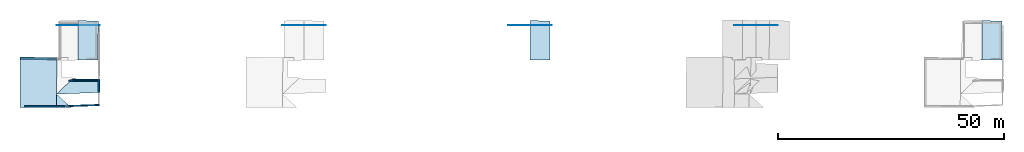
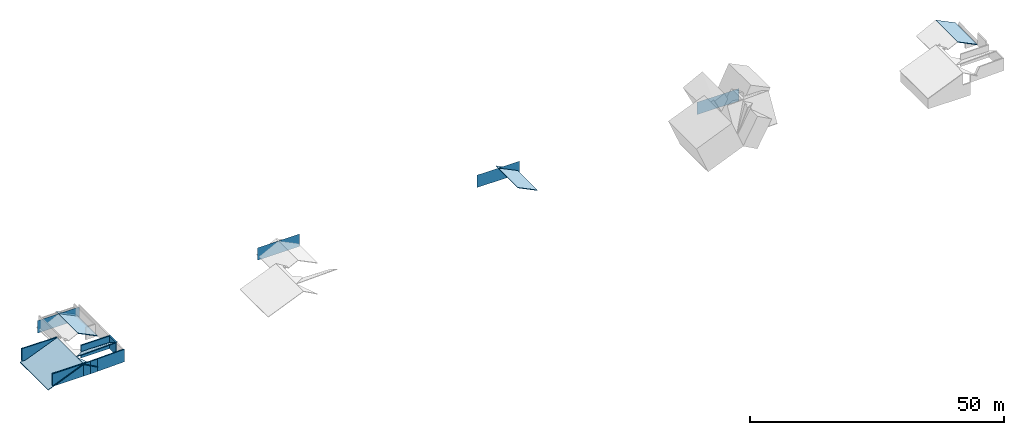
# One storey, part 1 of 4: 14 slabs, 14 walls.
"""IFC4 building model written with IfcOpenShell, lengths in metres."""

from ifc_helpers import new_model, entity, si_unit, converted_unit, frame, frame_2d, origin_with_axes, place, context, subcontext, project, spatial, indexed_curve, outline, extrude, clip, halfspace, polygons, material, layer, layer_set, layer_usage, type_object, element, save


model = new_model("IFC4")

# Units and contexts
model_context = context("Model", 3, precision=1e-05, world=origin_with_axes())
plan_context = context("Plan", 2, precision=1e-05, world=frame_2d((0.0, 0.0, 0.0), x_axis=(1.0, 0.0, 0.0)))
body_context = subcontext(model_context, "Body", "Model", "MODEL_VIEW")
ifc_project = project(units=[converted_unit("PLANEANGLEUNIT", "degree", entity("IfcReal", 0.0174532925199433), si_unit("PLANEANGLEUNIT", "RADIAN"), dimensions=[0, 0, 0, 0, 0, 0, 0]), si_unit("AREAUNIT", "SQUARE_METRE"), si_unit("VOLUMEUNIT", "CUBIC_METRE"), si_unit("LENGTHUNIT", "METRE")], contexts=[model_context, plan_context])

# Site, building, storey
site_placement = place(None, origin_with_axes())
site = spatial("IfcSite", under=ifc_project, at=site_placement)
building_placement = place(site_placement, origin_with_axes())
building = spatial("IfcBuilding", under=site, at=building_placement, Name="Building")
storey_placement = place(building_placement, frame((0.0, 0.0, 3.0), z_axis=(0.0, 0.0, 1.0), x_axis=(1.0, 0.0, 0.0)))
storey = spatial("IfcBuildingStorey", under=building, at=storey_placement, Name="Dachgeschoss")

# Slabs
slab_1_placement = place(storey_placement, frame((0.138327658176422, 11.9685554504395, -0.0325007438659668), z_axis=(-0.389843016862869, 1.06302975311223e-08, 0.920881330966949), x_axis=(0.920881330966949, -5.23788585837792e-08, 0.389843016862869)))
element("IfcSlab", 1, at=slab_1_placement, inside=storey, Name="roof_wohnen", PredefinedType="ROOF", context=body_context, shape_type="Tessellation", body=[
    polygons([(0.139375194907188, -0.0453592203557491, -0.456899970769882), (0.15936766564846, -11.2182168960571, -0.357028633356094), (0.0808987393975258, -0.0453592240810394, -0.595032215118408), (0.100891202688217, -11.2182168960571, -0.495160847902298), (8.96628284454346, -0.0885668694972992, -0.54577898979187), (8.88335037231445, -11.1898832321167, -0.415635466575623), (8.82487392425537, -11.1898832321167, -0.553767681121826), (8.90780639648438, -0.0885668694972992, -0.683911144733429)], [[[1, 5, 8, 3]], [[1, 3, 4, 2]], [[7, 6, 2, 4]], [[6, 7, 8, 5]], [[1, 6, 5]], [[3, 7, 4]], [[1, 2, 6]], [[3, 8, 7]]]),
])
slab_2_placement = place(storey_placement, frame((7.51337957382202, 18.4299716949463, 3.13837957382202), z_axis=(0.0, 0.0, 1.0), x_axis=(1.0, 0.0, 0.0)))
element("IfcSlab", 2, at=slab_2_placement, inside=storey, PredefinedType="ROOF", context=body_context, shape_type="Tessellation", body=[
    polygons([(0.967490494251251, -17.6513004302979, -0.0905194282531738), (4.19703483581543, -17.6393585205078, -1.87382221221924), (1.00142824649811, -14.6873569488525, -0.113885402679443), (1.00142824649811, -14.6873569488525, -0.263885408639908), (0.967490494251251, -17.6513004302979, -0.240519434213638), (4.19703483581543, -17.6393585205078, -2.02382230758667)], [[[3, 1, 2]], [[4, 6, 5]], [[3, 2, 6, 4]], [[2, 1, 5, 6]], [[1, 3, 4, 5]]]),
])
slab_3_placement = place(storey_placement, frame((8.51480770111084, 19.0338859558105, -0.612094879150391), z_axis=(0.0, 0.0, 1.0), x_axis=(1.0, 0.0, 0.0)))
element("IfcSlab", 3, at=slab_3_placement, inside=storey, Name="dach_n", PredefinedType="ROOF", context=body_context, shape_type="Clipping", body=[
    clip(extrude(outline(indexed_curve([(0.0, 0.0), (0.0, 0.0), (9.57009605941475, 0.0), (9.57009605941475, 0.0), (0.0, 0.0)], self_intersect=False)), origin_with_axes(), (0.0, 0.0, 1.0), 3.0), halfspace(frame((9.29009342193604, 0.0, -2.38790512084961), z_axis=(0.0, -0.549658119678497, 0.0), x_axis=(0.280002593994141, 0.0, 0.0)), False)),
])
slab_4_placement = place(storey_placement, frame((11.5073595046997, 19.0338859558105, -0.612094879150391), z_axis=(0.0, 0.0, 1.0), x_axis=(1.0, 0.0, 0.0)))
element("IfcSlab", 4, at=slab_4_placement, inside=storey, Name="dach_s", PredefinedType="ROOF", context=body_context, shape_type="Tessellation", body=[
    polygons([(-2.99255204200745, -15.2912702560425, 3.63658905029297), (6.61049318313599, -14.9145994186401, 3.63154697418213), (0.53916323184967, -11.8741445541382, 1.83055698871613), (6.67501163482666, -11.9667654037476, 1.80503046512604), (0.53916323184967, -11.8741445541382, 1.68055701255798), (-2.99255204200745, -15.2912702560425, 3.48658895492554), (6.61049318313599, -14.9145994186401, 3.4815468788147), (6.67501163482666, -11.9667654037476, 1.6550304889679)], [[[3, 2, 1]], [[7, 5, 6]], [[2, 4, 8, 7]], [[3, 6, 5]], [[4, 3, 5, 8]], [[1, 2, 7, 6]], [[3, 4, 2]], [[7, 8, 5]], [[3, 1, 6]]]),
])
slab_5_placement = place(storey_placement, frame((14.0933465957642, 19.4814624786377, 1.75806331634521), z_axis=(0.83547306060791, 6.05244423468321e-08, 0.54953134059906), x_axis=(0.54953134059906, 1.12253204065382e-07, -0.83547306060791)))
element("IfcSlab", 5, at=slab_5_placement, inside=storey, Name="dach_sw", PredefinedType="ROOF", context=body_context, shape_type="Tessellation", body=[
    polygons([(-1.04153060913086, -8.217942237854, -0.316155582666397), (3.25821256637573, -8.2083625793457, 2.20982432365417), (-0.953627169132233, 0.529778599739075, -0.311261177062988), (3.28126811981201, 0.463787794113159, 2.21388936042786), (-0.980952382087708, -2.60569453239441, -5.8044319152832), (-0.828306198120117, 0.529778599739075, -0.393690884113312), (-0.916209638118744, -8.217942237854, -0.398585289716721), (3.38353371620178, -8.2083625793457, 2.1273946762085), (3.40658903121948, 0.463787794113159, 2.13145971298218)], [[[1, 4, 2]], [[7, 9, 6]], [[2, 4, 9, 8]], [[3, 1, 7, 6]], [[4, 3, 6, 9]], [[1, 2, 8, 7]], [[1, 3, 4]], [[7, 8, 9]]]),
])
slab_6_placement = place(storey_placement, frame((0.138327658176422, 11.9685554504395, -0.0325007438659668), z_axis=(-0.389843016862869, 1.06302975311223e-08, 0.920881330966949), x_axis=(0.920881330966949, -5.23788585837792e-08, 0.389843016862869)))
element("IfcSlab", 6, at=slab_6_placement, inside=storey, Name="roof_wohnen", PredefinedType="ROOF", context=body_context, shape_type="Tessellation", body=[
    polygons([(0.139375194907188, -0.0453592203557491, -0.456899970769882), (0.15936766564846, -11.2182168960571, -0.357028633356094), (0.0808987393975258, -0.0453592240810394, -0.595032215118408), (0.100891202688217, -11.2182168960571, -0.495160847902298), (8.96628284454346, -0.0885668694972992, -0.54577898979187), (8.88335037231445, -11.1898832321167, -0.415635466575623), (8.82487392425537, -11.1898832321167, -0.553767681121826), (8.90780639648438, -0.0885668694972992, -0.683911144733429)], [[[1, 5, 8, 3]], [[1, 3, 4, 2]], [[7, 6, 2, 4]], [[6, 7, 8, 5]], [[1, 6, 5]], [[3, 7, 4]], [[1, 2, 6]], [[3, 8, 7]]]),
])
slab_7_placement = place(storey_placement, frame((11.5073595046997, 19.0338859558105, -0.612094879150391), z_axis=(0.0, 0.0, 1.0), x_axis=(1.0, 0.0, 0.0)))
element("IfcSlab", 7, at=slab_7_placement, inside=storey, Name="dach_s", PredefinedType="ROOF", context=body_context, shape_type="Tessellation", body=[
    polygons([(-2.99255204200745, -15.2912702560425, 3.63658905029297), (6.61049318313599, -14.9145994186401, 3.63154697418213), (0.53916323184967, -11.8741445541382, 1.83055698871613), (6.67501163482666, -11.9667654037476, 1.80503046512604), (0.53916323184967, -11.8741445541382, 1.68055701255798), (-2.99255204200745, -15.2912702560425, 3.48658895492554), (6.61049318313599, -14.9145994186401, 3.4815468788147), (6.67501163482666, -11.9667654037476, 1.6550304889679)], [[[3, 2, 1]], [[7, 5, 6]], [[2, 4, 8, 7]], [[3, 6, 5]], [[4, 3, 5, 8]], [[1, 2, 7, 6]], [[3, 4, 2]], [[7, 8, 5]], [[3, 1, 6]]]),
])
slab_8_placement = place(storey_placement, frame((7.51337957382202, 18.4299716949463, 3.13837957382202), z_axis=(0.0, 0.0, 1.0), x_axis=(1.0, 0.0, 0.0)))
element("IfcSlab", 8, at=slab_8_placement, inside=storey, PredefinedType="ROOF", context=body_context, shape_type="Tessellation", body=[
    polygons([(0.967490494251251, -17.6513004302979, -0.0905194282531738), (4.19703483581543, -17.6393585205078, -1.87382221221924), (1.00142824649811, -14.6873569488525, -0.113885402679443), (1.00142824649811, -14.6873569488525, -0.263885408639908), (0.967490494251251, -17.6513004302979, -0.240519434213638), (4.19703483581543, -17.6393585205078, -2.02382230758667)], [[[3, 1, 2]], [[4, 6, 5]], [[3, 2, 6, 4]], [[2, 1, 5, 6]], [[1, 3, 4, 5]]]),
])
for number, where, z_axis, x_axis, name in (
    (9, (58.5148086547852, 19.0338859558105, -0.612094879150391), (0.0, 0.0, 1.0), (1.0, 0.0, 0.0), "dach_n"),
    (10, (108.514808654785, 19.0338859558105, -0.612094879150391), (0.0, 0.0, 1.0), (1.0, 0.0, 0.0), "dach_n"),
):
    element("IfcSlab", number, at=place(storey_placement, frame(where, z_axis=z_axis, x_axis=x_axis)), inside=storey, Name=name, PredefinedType="ROOF", context=body_context, shape_type="Clipping", body=[
        clip(extrude(outline(indexed_curve([(0.0, 0.0), (0.0, 0.0), (9.57009605941475, 0.0), (9.57009605941475, 0.0), (0.0, 0.0)], self_intersect=False)), origin_with_axes(), (0.0, 0.0, 1.0), 3.0), halfspace(frame((9.29009342193604, 0.0, -2.38790512084961), z_axis=(0.0, -0.549658119678497, 0.0), x_axis=(0.280002593994141, 0.0, 0.0)), False)),
    ])
slab_9_placement = place(storey_placement, frame((114.09334564209, 19.4814624786377, 1.75806331634521), z_axis=(0.835473120212555, 6.05244707685415e-08, 0.549531161785126), x_axis=(0.549531161785126, 1.1225321117081e-07, -0.835473120212555)))
element("IfcSlab", 11, at=slab_9_placement, inside=storey, Name="dach_sw", PredefinedType="ROOF", context=body_context, shape_type="Tessellation", body=[
    polygons([(-1.04153060913086, -8.217942237854, -0.316155582666397), (3.25821256637573, -8.2083625793457, 2.20982432365417), (-0.953627169132233, 0.529778599739075, -0.311261177062988), (3.28126811981201, 0.463787794113159, 2.21388936042786), (-0.980952382087708, -2.60569453239441, -5.8044319152832), (-0.828306198120117, 0.529778599739075, -0.393690884113312), (-0.916209638118744, -8.217942237854, -0.398585289716721), (3.38353371620178, -8.2083625793457, 2.1273946762085), (3.40658903121948, 0.463787794113159, 2.13145971298218)], [[[1, 4, 2]], [[7, 9, 6]], [[2, 4, 9, 8]], [[3, 1, 7, 6]], [[4, 3, 6, 9]], [[1, 2, 8, 7]], [[1, 3, 4]], [[7, 8, 9]]]),
])
slab_10_placement = place(storey_placement, frame((158.514801025391, 19.0338859558105, -0.612094879150391), z_axis=(0.0, 0.0, 1.0), x_axis=(1.0, 0.0, 0.0)))
element("IfcSlab", 12, at=slab_10_placement, inside=storey, Name="dach_n", PredefinedType="ROOF", context=body_context, shape_type="Clipping", body=[
    clip(extrude(outline(indexed_curve([(0.0, 0.0), (0.0, 0.0), (9.57009605941475, 0.0), (9.57009605941475, 0.0), (0.0, 0.0)], self_intersect=False)), origin_with_axes(), (0.0, 0.0, 1.0), 3.0), halfspace(frame((9.29009342193604, 0.0, -2.38790512084961), z_axis=(0.0, -0.549658119678497, 0.0), x_axis=(0.280002593994141, 0.0, 0.0)), False)),
])
for number, where, z_axis, x_axis, name in (
    (13, (14.0933465957642, 19.4814624786377, 1.75806331634521), (0.83547306060791, 6.05244423468321e-08, 0.54953134059906), (0.54953134059906, 1.12253204065382e-07, -0.83547306060791), "dach_sw"),
    (14, (214.093353271484, 19.4814624786377, 1.75806331634521), (0.835473120212555, 6.05244707685415e-08, 0.549531161785126), (0.549531161785126, 1.1225321117081e-07, -0.835473120212555), "dach_sw"),
):
    element("IfcSlab", number, at=place(storey_placement, frame(where, z_axis=z_axis, x_axis=x_axis)), inside=storey, Name=name, PredefinedType="ROOF", context=body_context, shape_type="Tessellation", body=[
        polygons([(-1.04153060913086, -8.217942237854, -0.316155582666397), (3.25821256637573, -8.2083625793457, 2.20982432365417), (-0.953627169132233, 0.529778599739075, -0.311261177062988), (3.28126811981201, 0.463787794113159, 2.21388936042786), (-0.980952382087708, -2.60569453239441, -5.8044319152832), (-0.828306198120117, 0.529778599739075, -0.393690884113312), (-0.916209638118744, -8.217942237854, -0.398585289716721), (3.38353371620178, -8.2083625793457, 2.1273946762085), (3.40658903121948, 0.463787794113159, 2.13145971298218)], [[[1, 4, 2]], [[7, 9, 6]], [[2, 4, 9, 8]], [[3, 1, 7, 6]], [[4, 3, 6, 9]], [[1, 2, 8, 7]], [[1, 3, 4]], [[7, 8, 9]]]),
    ])

# Walls
ifc_material = material(Name="aussenwand_280_material")
ifc_layer = layer(ifc_material, 0.280000001192093)
ifc_layer_set = layer_set([ifc_layer])
ifc_layer_usage_1 = layer_usage(ifc_layer_set, "AXIS2", "POSITIVE", 0.0)
wall_type = type_object("IfcWallType", Name="aussenwand_280", PredefinedType="STANDARD", material=ifc_layer_set)
wall_1_placement = place(storey_placement, frame((1.50885987281799, 0.922550857067108, -2.38418579101563e-07), z_axis=(0.0, 0.0, 1.0), x_axis=(0.999999582767487, 0.000923240790143609, 0.0)))
element("IfcWall", 15, at=wall_1_placement, inside=storey, type_object=wall_type, material=ifc_layer_usage_1, Name="Wall", PredefinedType="NOTDEFINED", context=body_context, shape_type="SweptSolid", body=[
    extrude(outline(indexed_curve([(0.0, 0.0), (0.0, 0.280000001192093), (6.97187437102741, 0.280000001192093), (6.97187437102741, 0.0), (0.0, 0.0)], self_intersect=False)), origin_with_axes(), (0.0, 0.0, 1.0), 3.0),
])
ifc_layer_usage_2 = layer_usage(ifc_layer_set, "AXIS2", "POSITIVE", 0.0)
wall_2_placement = place(storey_placement, frame((10.1700124740601, 0.931393384933472, -2.38418579101563e-07), z_axis=(0.0, 0.0, 1.0), x_axis=(0.999382197856903, 0.0351415351033211, 0.0)))
element("IfcWall", 16, at=wall_2_placement, inside=storey, type_object=wall_type, material=ifc_layer_usage_2, Name="Wall", PredefinedType="NOTDEFINED", context=body_context, shape_type="SweptSolid", body=[
    extrude(outline(indexed_curve([(0.0, 0.0), (0.0, 0.280000001192093), (1.53450472655644, 0.280000001192093), (1.53450472655644, 0.0), (0.0, 0.0)], self_intersect=False)), origin_with_axes(), (0.0, 0.0, 1.0), 3.0),
])
ifc_layer_usage_3 = layer_usage(ifc_layer_set, "AXIS2", "POSITIVE", 0.0)
wall_3_placement = place(storey_placement, frame((17.7329654693604, 6.90121555328369, -2.38418579101563e-07), z_axis=(0.0, 0.0, 1.0), x_axis=(-0.999989092350006, -0.00467242300510406, 0.0)))
element("IfcWall", 17, at=wall_3_placement, inside=storey, type_object=wall_type, material=ifc_layer_usage_3, Name="Wall", PredefinedType="NOTDEFINED", context=body_context, shape_type="SweptSolid", body=[
    extrude(outline(indexed_curve([(0.0, 0.0), (0.0, 0.280000001192093), (6.4844628440617, 0.280000001192093), (6.4844628440617, 0.0), (0.0, 0.0)], self_intersect=False)), origin_with_axes(), (0.0, 0.0, 1.0), 3.0),
])
ifc_layer_usage_4 = layer_usage(ifc_layer_set, "AXIS2", "POSITIVE", 0.0)
wall_4_placement = place(storey_placement, frame((17.732982635498, 6.90418434143066, -2.38418579101563e-07), z_axis=(0.0, 0.0, 1.0), x_axis=(-0.00592900207266212, -0.999982416629791, 0.0)))
element("IfcWall", 18, at=wall_4_placement, inside=storey, type_object=wall_type, material=ifc_layer_usage_4, Name="Wall", PredefinedType="NOTDEFINED", context=body_context, shape_type="SweptSolid", body=[
    extrude(outline(indexed_curve([(0.0, 0.0), (0.0, 0.280000001192093), (2.78256681753973, 0.280000001192093), (2.78256681753973, 0.0), (0.0, 0.0)], self_intersect=False)), origin_with_axes(), (0.0, 0.0, 1.0), 3.0),
])
ifc_layer_usage_5 = layer_usage(ifc_layer_set, "AXIS2", "POSITIVE", 0.0)
wall_5_placement = place(storey_placement, frame((8.4807300567627, 0.929833590984344, -2.38418579101563e-07), z_axis=(0.0, 0.0, 1.0), x_axis=(0.999999582767487, 0.000923240790143609, 0.0)))
element("IfcWall", 19, at=wall_5_placement, inside=storey, type_object=wall_type, material=ifc_layer_usage_5, Name="Wall", PredefinedType="NOTDEFINED", context=body_context, shape_type="SweptSolid", body=[
    extrude(outline(indexed_curve([(0.0, 0.0), (0.0, 0.280000001192093), (1.68927835094324, 0.280000001192093), (1.68927835094324, 0.0), (0.0, 0.0)], self_intersect=False)), origin_with_axes(), (0.0, 0.0, 1.0), 3.0),
])
ifc_layer_usage_6 = layer_usage(ifc_layer_set, "AXIS2", "POSITIVE", 0.0)
wall_6_placement = place(storey_placement, frame((11.7035694122314, 0.985318243503571, -2.38418579101563e-07), z_axis=(0.0, 0.0, 1.0), x_axis=(0.999382138252258, 0.0351415351033211, 0.0)))
element("IfcWall", 20, at=wall_6_placement, inside=storey, type_object=wall_type, material=ifc_layer_usage_6, Name="Wall", PredefinedType="NOTDEFINED", context=body_context, shape_type="SweptSolid", body=[
    extrude(outline(indexed_curve([(0.0, 0.0), (0.0, 0.280000001192093), (6.29101780503812, 0.280000001192093), (6.29101780503812, 0.0), (0.0, 0.0)], self_intersect=False)), origin_with_axes(), (0.0, 0.0, 1.0), 3.0),
])
ifc_layer_usage_7 = layer_usage(ifc_layer_set, "AXIS2", "POSITIVE", 0.0)
wall_7_placement = place(storey_placement, frame((8.60610389709473, 11.6690664291382, -0.0010533332824707), z_axis=(0.0, 0.0, 1.0), x_axis=(-0.999960541725159, 0.00888374913483858, 0.0)))
element("IfcWall", 21, at=wall_7_placement, inside=storey, type_object=wall_type, material=ifc_layer_usage_7, Name="Wall", PredefinedType="NOTDEFINED", context=body_context, shape_type="SweptSolid", body=[
    extrude(outline(indexed_curve([(0.0, 0.0), (0.0, 0.280000001192093), (8.01390124085017, 0.280000001192093), (8.01390124085017, 0.0), (0.0, 0.0)], self_intersect=False)), origin_with_axes(), (0.0, 0.0, 1.0), 3.0),
])
ifc_layer_usage_8 = layer_usage(ifc_layer_set, "AXIS2", "POSITIVE", 0.0)
wall_8_placement = place(storey_placement, frame((1.50885987281799, 0.922550857067108, -2.38418579101563e-07), z_axis=(0.0, 0.0, 1.0), x_axis=(0.999999582767487, 0.000923240790143609, 0.0)))
element("IfcWall", 22, at=wall_8_placement, inside=storey, type_object=wall_type, material=ifc_layer_usage_8, Name="Wall", PredefinedType="NOTDEFINED", context=body_context, shape_type="SweptSolid", body=[
    extrude(outline(indexed_curve([(0.0, 0.0), (0.0, 0.280000001192093), (6.97187437102741, 0.280000001192093), (6.97187437102741, 0.0), (0.0, 0.0)], self_intersect=False)), origin_with_axes(), (0.0, 0.0, 1.0), 3.0),
])
ifc_layer_usage_9 = layer_usage(ifc_layer_set, "AXIS2", "POSITIVE", 0.0)
wall_9_placement = place(storey_placement, frame((8.60610389709473, 11.6690664291382, -0.0010533332824707), z_axis=(0.0, 0.0, 1.0), x_axis=(-0.999960541725159, 0.00888374913483858, 0.0)))
element("IfcWall", 23, at=wall_9_placement, inside=storey, type_object=wall_type, material=ifc_layer_usage_9, Name="Wall", PredefinedType="NOTDEFINED", context=body_context, shape_type="SweptSolid", body=[
    extrude(outline(indexed_curve([(0.0, 0.0), (0.0, 0.280000001192093), (8.01390124085017, 0.280000001192093), (8.01390124085017, 0.0), (0.0, 0.0)], self_intersect=False)), origin_with_axes(), (0.0, 0.0, 1.0), 3.0),
])
ifc_layer_usage_10 = layer_usage(ifc_layer_set, "AXIS2", "POSITIVE", 0.0)
wall_10_placement = place(storey_placement, frame((8.4807300567627, 0.929833590984344, -2.38418579101563e-07), z_axis=(0.0, 0.0, 1.0), x_axis=(0.999999582767487, 0.000923240790143609, 0.0)))
element("IfcWall", 24, at=wall_10_placement, inside=storey, type_object=wall_type, material=ifc_layer_usage_10, Name="Wall", PredefinedType="NOTDEFINED", context=body_context, shape_type="SweptSolid", body=[
    extrude(outline(indexed_curve([(0.0, 0.0), (0.0, 0.280000001192093), (1.68927835094324, 0.280000001192093), (1.68927835094324, 0.0), (0.0, 0.0)], self_intersect=False)), origin_with_axes(), (0.0, 0.0, 1.0), 3.0),
])
ifc_layer_usage_11 = layer_usage(ifc_layer_set, "AXIS2", "POSITIVE", 0.0)
wall_11_placement = place(storey_placement, frame((17.732982635498, 6.90418434143066, -2.38418579101563e-07), z_axis=(0.0, 0.0, 1.0), x_axis=(-0.00592900207266212, -0.999982416629791, 0.0)))
element("IfcWall", 25, at=wall_11_placement, inside=storey, type_object=wall_type, material=ifc_layer_usage_11, Name="Wall", PredefinedType="NOTDEFINED", context=body_context, shape_type="SweptSolid", body=[
    extrude(outline(indexed_curve([(0.0, 0.0), (0.0, 0.280000001192093), (2.78256681753973, 0.280000001192093), (2.78256681753973, 0.0), (0.0, 0.0)], self_intersect=False)), origin_with_axes(), (0.0, 0.0, 1.0), 3.0),
])
ifc_layer_usage_12 = layer_usage(ifc_layer_set, "AXIS2", "POSITIVE", 0.0)
wall_12_placement = place(storey_placement, frame((11.7035694122314, 0.985318243503571, -2.38418579101563e-07), z_axis=(0.0, 0.0, 1.0), x_axis=(0.999382138252258, 0.0351415351033211, 0.0)))
element("IfcWall", 26, at=wall_12_placement, inside=storey, type_object=wall_type, material=ifc_layer_usage_12, Name="Wall", PredefinedType="NOTDEFINED", context=body_context, shape_type="SweptSolid", body=[
    extrude(outline(indexed_curve([(0.0, 0.0), (0.0, 0.280000001192093), (6.29101780503812, 0.280000001192093), (6.29101780503812, 0.0), (0.0, 0.0)], self_intersect=False)), origin_with_axes(), (0.0, 0.0, 1.0), 3.0),
])
ifc_layer_usage_13 = layer_usage(ifc_layer_set, "AXIS2", "POSITIVE", 0.0)
wall_13_placement = place(storey_placement, frame((10.1700124740601, 0.931393384933472, -2.38418579101563e-07), z_axis=(0.0, 0.0, 1.0), x_axis=(0.999382197856903, 0.0351415351033211, 0.0)))
element("IfcWall", 27, at=wall_13_placement, inside=storey, type_object=wall_type, material=ifc_layer_usage_13, Name="Wall", PredefinedType="NOTDEFINED", context=body_context, shape_type="SweptSolid", body=[
    extrude(outline(indexed_curve([(0.0, 0.0), (0.0, 0.280000001192093), (1.53450472655644, 0.280000001192093), (1.53450472655644, 0.0), (0.0, 0.0)], self_intersect=False)), origin_with_axes(), (0.0, 0.0, 1.0), 3.0),
])
ifc_layer_usage_14 = layer_usage(ifc_layer_set, "AXIS2", "POSITIVE", 0.0)
wall_14_placement = place(storey_placement, frame((17.7329654693604, 6.90121555328369, -2.38418579101563e-07), z_axis=(0.0, 0.0, 1.0), x_axis=(-0.999989092350006, -0.00467242300510406, 0.0)))
element("IfcWall", 28, at=wall_14_placement, inside=storey, type_object=wall_type, material=ifc_layer_usage_14, Name="Wall", PredefinedType="NOTDEFINED", context=body_context, shape_type="SweptSolid", body=[
    extrude(outline(indexed_curve([(0.0, 0.0), (0.0, 0.280000001192093), (6.4844628440617, 0.280000001192093), (6.4844628440617, 0.0), (0.0, 0.0)], self_intersect=False)), origin_with_axes(), (0.0, 0.0, 1.0), 3.0),
])

save(model, "model.ifc")
